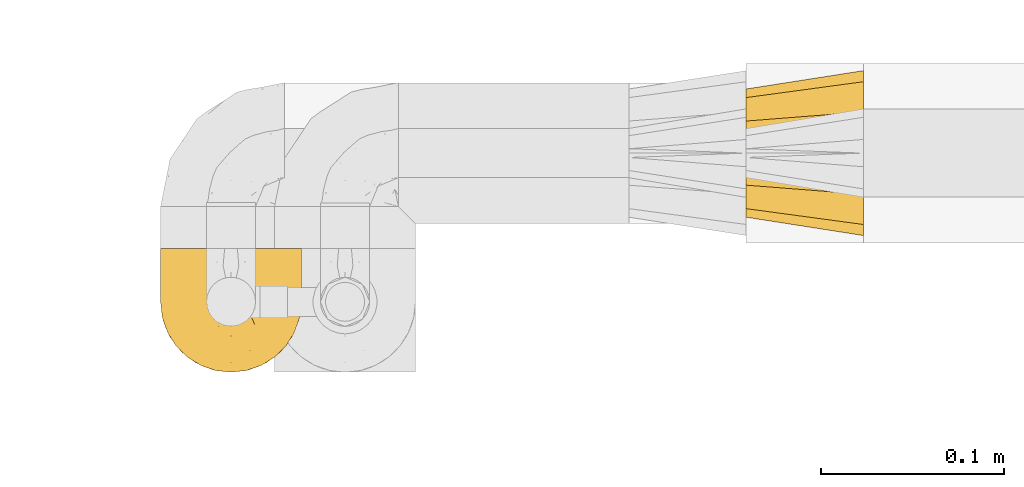
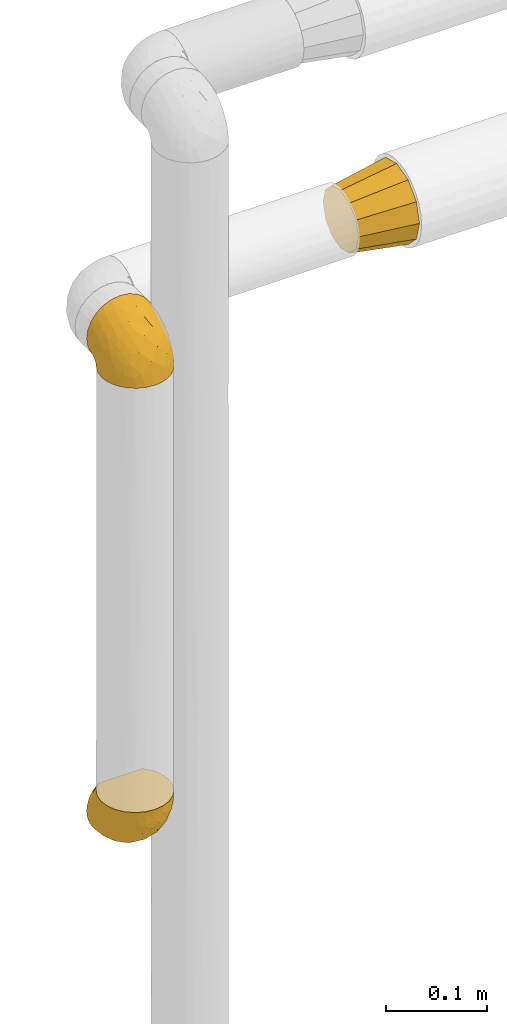
# One storey, part 334 of 827: 3 coverings.
"""IFC2X3 building model written with IfcOpenShell, lengths in millimetres."""

from ifc_helpers import new_model, entity, si_unit, converted_unit, derived_unit, direction, frame, origin, place, context, subcontext, project, spatial, faceted_brep, element, save


model = new_model("IFC2X3")

# Units and contexts
model_context = context("Model", 3, precision=0.01, world=origin(), true_north=direction((6.12303176911189e-17, 1.0)))
body_context = subcontext(model_context, "Body", "Model", "MODEL_VIEW")
ifc_project = project(units=[si_unit("LENGTHUNIT", "METRE", prefix="MILLI"), si_unit("AREAUNIT", "SQUARE_METRE"), si_unit("VOLUMEUNIT", "CUBIC_METRE"), converted_unit("PLANEANGLEUNIT", "DEGREE", entity("IfcRatioMeasure", 0.0174532925199433), si_unit("PLANEANGLEUNIT", "RADIAN"), dimensions=[0, 0, 0, 0, 0, 0, 0]), si_unit("MASSUNIT", "GRAM", prefix="KILO"), derived_unit("MASSDENSITYUNIT", [(si_unit("MASSUNIT", "GRAM", prefix="KILO"), 1), (si_unit("LENGTHUNIT", "METRE"), -3)]), derived_unit("MOMENTOFINERTIAUNIT", [(si_unit("LENGTHUNIT", "METRE"), 4)]), si_unit("TIMEUNIT", "SECOND"), si_unit("FREQUENCYUNIT", "HERTZ"), si_unit("THERMODYNAMICTEMPERATUREUNIT", "DEGREE_CELSIUS"), derived_unit("THERMALTRANSMITTANCEUNIT", [(si_unit("MASSUNIT", "GRAM", prefix="KILO"), 1), (si_unit("THERMODYNAMICTEMPERATUREUNIT", "KELVIN"), -1), (si_unit("TIMEUNIT", "SECOND"), -3)]), derived_unit("VOLUMETRICFLOWRATEUNIT", [(si_unit("LENGTHUNIT", "METRE"), 3), (si_unit("TIMEUNIT", "SECOND"), -1)]), derived_unit("MASSFLOWRATEUNIT", [(si_unit("MASSUNIT", "GRAM", prefix="KILO"), 1), (si_unit("TIMEUNIT", "SECOND"), -1)]), derived_unit("ROTATIONALFREQUENCYUNIT", [(si_unit("TIMEUNIT", "SECOND"), -1)]), si_unit("ELECTRICCURRENTUNIT", "AMPERE"), si_unit("ELECTRICVOLTAGEUNIT", "VOLT"), si_unit("POWERUNIT", "WATT"), si_unit("FORCEUNIT", "NEWTON", prefix="KILO"), si_unit("ILLUMINANCEUNIT", "LUX"), si_unit("LUMINOUSFLUXUNIT", "LUMEN"), si_unit("LUMINOUSINTENSITYUNIT", "CANDELA"), derived_unit("USERDEFINED", [(si_unit("MASSUNIT", "GRAM", prefix="KILO"), -1), (si_unit("LENGTHUNIT", "METRE"), -2), (si_unit("TIMEUNIT", "SECOND"), 3), (si_unit("LUMINOUSFLUXUNIT", "LUMEN"), 1)]), derived_unit("LINEARVELOCITYUNIT", [(si_unit("LENGTHUNIT", "METRE"), 1), (si_unit("TIMEUNIT", "SECOND"), -1)]), si_unit("PRESSUREUNIT", "PASCAL"), derived_unit("USERDEFINED", [(si_unit("LENGTHUNIT", "METRE"), -2), (si_unit("MASSUNIT", "GRAM", prefix="KILO"), 1), (si_unit("TIMEUNIT", "SECOND"), -2)]), derived_unit("LINEARFORCEUNIT", [(si_unit("MASSUNIT", "GRAM", prefix="KILO"), 1), (si_unit("LENGTHUNIT", "METRE"), 1), (si_unit("TIMEUNIT", "SECOND"), -2), (si_unit("LENGTHUNIT", "METRE"), -1)]), derived_unit("PLANARFORCEUNIT", [(si_unit("MASSUNIT", "GRAM", prefix="KILO"), 1), (si_unit("LENGTHUNIT", "METRE"), 1), (si_unit("TIMEUNIT", "SECOND"), -2), (si_unit("LENGTHUNIT", "METRE"), -2)])], contexts=[model_context])

# Site, building, storey
site_placement = place(None, origin())
site = spatial("IfcSite", under=ifc_project, at=site_placement, CompositionType="ELEMENT")
building_placement = place(site_placement, origin())
building = spatial("IfcBuilding", under=site, at=building_placement, CompositionType="ELEMENT")
storey_placement = place(building_placement, frame((0.0, 0.0, 28200.0)))
storey = spatial("IfcBuildingStorey", under=building, at=storey_placement, Name="08", CompositionType="ELEMENT", Elevation=28200.0)

# Coverings
covering_1_placement = place(storey_placement, frame((34953.73, 19373.39, 1669.3)))
element("IfcCovering", 1, at=covering_1_placement, inside=storey, Name=":ADSK_", ObjectType=":ADSK_", PredefinedType="INSULATION", context=body_context, shape_type="Brep", body=[
    faceted_brep([(74.68, 23.36, 1.6), (70.1, 16.07, 1.6), (64.01, 9.98, 1.6), (56.72, 5.4, 1.6), (48.6, 2.56, 1.6), (40.05, 1.6, 1.6), (31.49, 2.56, 1.6), (23.36, 5.41, 1.6), (16.07, 9.99, 1.6), (9.98, 16.08, 1.6), (5.4, 23.37, 1.6), (2.56, 31.49, 1.6), (1.6, 40.05, 1.6), (2.46, 48.15, 1.6), (5.01, 55.88, 1.6), (9.13, 62.9, 1.6), (14.62, 68.89, 1.6), (16.82, 68.89, 1.6), (18.56, 68.89, 1.6), (20.52, 68.89, 1.6), (22.49, 68.89, 1.6), (24.46, 68.89, 1.6), (26.42, 68.89, 1.6), (28.39, 68.89, 1.6), (30.36, 68.89, 1.6), (32.55, 68.89, 1.6), (34.75, 68.89, 1.6), (36.94, 68.89, 1.6), (39.13, 68.89, 1.6), (41.33, 68.89, 1.6), (43.52, 68.89, 1.6), (45.72, 68.89, 1.6), (47.91, 68.89, 1.6), (50.11, 68.89, 1.6), (52.3, 68.89, 1.6), (54.49, 68.89, 1.6), (56.69, 68.89, 1.6), (58.88, 68.89, 1.6), (61.08, 68.89, 1.6), (63.27, 68.89, 1.6), (65.47, 68.89, 1.6), (70.97, 62.89, 1.6), (75.09, 55.86, 1.6), (77.64, 48.13, 1.6), (78.5, 40.05, 1.6), (77.53, 31.49, 1.6), (14.62, 69.15, 1.85), (9.12, 69.15, 7.85), (5.0, 69.15, 14.87), (2.46, 69.15, 22.6), (1.6, 69.15, 30.7), (2.91, 69.15, 40.65), (6.75, 69.15, 49.92), (12.86, 69.15, 57.88), (20.82, 69.15, 63.99), (30.09, 69.15, 67.84), (40.05, 69.15, 69.15), (50.0, 69.15, 67.84), (59.27, 69.15, 63.99), (67.23, 69.15, 57.88), (73.34, 69.15, 49.92), (77.19, 69.15, 40.65), (78.5, 69.15, 30.7), (77.63, 69.15, 22.6), (75.09, 69.15, 14.87), (70.97, 69.15, 7.85), (65.47, 69.15, 1.85), (63.27, 69.15, 1.85), (62.29, 69.15, 1.85), (60.7, 69.15, 1.85), (59.11, 69.15, 1.85), (57.52, 69.15, 1.85), (55.93, 69.15, 1.85), (54.34, 69.15, 1.85), (52.76, 69.15, 1.85), (51.17, 69.15, 1.85), (49.58, 69.15, 1.85), (47.99, 69.15, 1.85), (46.4, 69.15, 1.85), (44.81, 69.15, 1.85), (43.22, 69.15, 1.85), (41.63, 69.15, 1.85), (40.05, 69.15, 1.85), (38.46, 69.15, 1.85), (36.87, 69.15, 1.85), (35.28, 69.15, 1.85), (33.69, 69.15, 1.85), (32.1, 69.15, 1.85), (30.51, 69.15, 1.85), (28.92, 69.15, 1.85), (27.33, 69.15, 1.85), (25.37, 69.15, 1.85), (23.4, 69.15, 1.85), (21.21, 69.15, 1.85), (19.01, 69.15, 1.85), (16.82, 69.15, 1.85), (42.32, 68.96, 1.77), (44.02, 68.97, 1.78), (47.13, 68.97, 1.77), (48.74, 68.97, 1.77), (23.57, 68.95, 1.76), (25.13, 68.96, 1.77), (61.34, 68.98, 1.79), (22.02, 68.97, 1.78), (29.72, 68.97, 1.78), (56.73, 68.98, 1.78), (55.14, 68.97, 1.78), (37.66, 68.97, 1.78), (64.12, 68.94, 1.74), (28.13, 68.98, 1.78), (26.62, 68.98, 1.78), (31.46, 68.96, 1.77), (16.16, 68.97, 1.78), (39.16, 68.98, 1.78), (50.37, 68.98, 1.78), (17.69, 68.97, 1.77), (19.17, 68.96, 1.77), (62.78, 68.97, 1.77), (58.35, 68.97, 1.78), (45.53, 68.98, 1.78), (59.91, 68.96, 1.77), (65.47, 68.97, 1.77), (65.47, 68.94, 1.72), (65.47, 68.92, 1.66), (14.62, 68.97, 1.77), (14.62, 69.02, 1.8), (14.62, 69.08, 1.82), (20.59, 68.98, 1.79), (32.99, 68.97, 1.78), (34.48, 68.98, 1.79), (51.91, 68.97, 1.78), (65.47, 69.08, 1.82), (65.47, 69.02, 1.8), (53.48, 68.96, 1.76), (14.62, 68.92, 1.66), (14.62, 68.94, 1.72), (40.77, 68.97, 1.78), (35.97, 68.96, 1.77), (7.84, 67.02, 9.41), (3.53, 63.33, 17.65), (8.32, 64.61, 7.41), (1.6, 49.27, 21.47), (2.19, 51.4, 15.21), (1.6, 43.94, 16.15), (1.6, 61.87, 28.75), (4.57, 61.54, 13.67), (3.96, 57.95, 12.79), (2.28, 56.12, 19.18), (1.6, 63.4, 29.16), (7.69, 65.41, 9.04), (3.53, 53.1, 7.41), (8.32, 63.04, 5.74), (7.84, 61.33, 3.72), (1.6, 41.99, 8.87), (1.6, 54.6, 26.8), (4.34, 56.6, 9.53), (1.6, 41.58, 7.34), (29.63, 13.72, 37.63), (27.34, 5.82, 17.92), (40.05, 6.74, 27.45), (2.39, 58.82, 37.01), (2.43, 51.58, 34.22), (9.07, 42.09, 45.87), (16.64, 46.12, 56.57), (9.54, 55.56, 52.31), (4.52, 52.38, 42.07), (4.52, 61.54, 44.74), (7.49, 23.76, 21.49), (7.49, 20.5, 11.02), (12.85, 14.64, 15.64), (2.35, 41.77, 26.02), (22.66, 16.28, 36.59), (32.9, 49.4, 65.49), (25.33, 52.34, 63.99), (40.05, 4.3, 15.2), (16.64, 58.67, 60.27), (19.99, 25.26, 45.25), (16.37, 20.17, 35.21), (3.26, 34.7, 22.52), (3.75, 28.67, 12.03), (19.58, 8.62, 13.32), (7.5, 33.37, 35.9), (4.04, 41.35, 33.87), (13.94, 17.15, 25.73), (19.58, 12.68, 26.34), (28.21, 21.47, 46.78), (24.75, 41.11, 59.54), (31.42, 37.53, 60.18), (26.2, 30.64, 53.93), (33.36, 26.66, 53.36), (40.05, 21.38, 49.36), (40.05, 14.06, 38.4), (40.05, 55.54, 66.44), (16.14, 35.17, 50.09), (12.85, 29.04, 41.08), (10.47, 24.34, 31.14), (6.49, 29.33, 28.19), (40.05, 43.3, 64.0), (40.05, 32.34, 56.68), (75.57, 57.75, 43.9), (47.37, 49.41, 65.46), (52.91, 27.85, 52.22), (50.46, 13.7, 37.61), (67.23, 14.63, 15.64), (60.5, 8.61, 13.31), (70.55, 48.85, 50.02), (63.45, 54.13, 59.28), (62.61, 37.84, 53.05), (72.6, 23.75, 21.48), (72.6, 20.49, 11.01), (76.34, 28.66, 12.03), (59.34, 20.83, 41.02), (77.76, 55.15, 35.39), (78.5, 54.6, 26.8), (78.5, 61.87, 28.75), (78.5, 41.58, 7.34), (53.16, 57.58, 65.81), (70.55, 59.91, 53.28), (48.88, 36.94, 59.8), (54.76, 45.72, 61.82), (52.74, 5.82, 17.91), (71.93, 37.91, 41.4), (75.79, 50.18, 40.48), (60.5, 12.67, 26.34), (77.86, 49.29, 31.68), (77.64, 42.64, 27.68), (78.5, 43.94, 16.15), (78.5, 49.27, 21.47), (67.23, 19.45, 28.05), (76.82, 34.7, 22.54), (78.5, 41.99, 8.87), (77.8, 62.29, 37.3), (67.23, 29.01, 41.07), (73.2, 31.47, 32.24), (67.66, 37.18, 47.4), (75.99, 43.45, 35.77), (76.57, 63.33, 17.65), (73.21, 67.23, 11.06), (71.93, 66.07, 8.55), (71.07, 65.22, 6.63), (75.09, 61.99, 12.77), (76.13, 57.95, 12.79), (76.57, 53.09, 7.41), (77.69, 56.84, 18.97), (72.26, 61.33, 3.72), (71.77, 63.06, 5.76), (77.9, 51.41, 15.21), (75.75, 56.61, 9.52)], [[[0, 1, 2, 3, 4, 5, 6, 7, 8, 9, 10, 11, 12, 13, 14, 15, 16, 17, 18, 19, 20, 21, 22, 23, 24, 25, 26, 27, 28, 29, 30, 31, 32, 33, 34, 35, 36, 37, 38, 39, 40, 41, 42, 43, 44, 45]], [[46, 47, 48, 49, 50, 51, 52, 53, 54, 55, 56, 57, 58, 59, 60, 61, 62, 63, 64, 65, 66, 67, 68, 69, 70, 71, 72, 73, 74, 75, 76, 77, 78, 79, 80, 81, 82, 83, 84, 85, 86, 87, 88, 89, 90, 91, 92, 93, 94, 95]], [[96, 97, 30]], [[98, 77, 99]], [[100, 101, 21]], [[69, 68, 102]], [[20, 19, 103]], [[24, 23, 104]], [[20, 103, 100]], [[72, 105, 106]], [[84, 83, 107]], [[89, 88, 104]], [[108, 67, 66]], [[109, 110, 90]], [[111, 25, 24]], [[112, 17, 16]], [[82, 113, 83]], [[109, 23, 22]], [[114, 76, 75]], [[105, 36, 106]], [[104, 111, 24]], [[18, 115, 116]], [[97, 96, 80]], [[67, 108, 117]], [[105, 71, 118]], [[31, 97, 119]], [[102, 120, 69]], [[108, 121, 122, 123, 40]], [[112, 95, 115]], [[17, 115, 18]], [[94, 116, 115]], [[117, 68, 67]], [[38, 117, 39]], [[112, 124, 125, 126, 46]], [[17, 112, 115]], [[70, 120, 118]], [[39, 117, 108]], [[120, 38, 37]], [[120, 37, 118]], [[120, 70, 69]], [[116, 94, 127]], [[128, 86, 129]], [[117, 38, 102]], [[74, 130, 75]], [[99, 33, 32]], [[115, 95, 94]], [[39, 108, 40]], [[108, 66, 131, 132, 121]], [[105, 72, 71]], [[118, 37, 36]], [[71, 70, 118]], [[35, 106, 36]], [[36, 105, 118]], [[35, 133, 106]], [[74, 73, 133]], [[106, 133, 73]], [[99, 114, 33]], [[133, 35, 34]], [[73, 72, 106]], [[95, 112, 46]], [[112, 16, 134, 135, 124]], [[130, 114, 75]], [[99, 76, 114]], [[114, 130, 33]], [[34, 33, 130]], [[78, 77, 98]], [[98, 119, 78]], [[130, 133, 34]], [[133, 130, 74]], [[79, 97, 80]], [[98, 99, 32]], [[98, 32, 31]], [[77, 76, 99]], [[97, 79, 119]], [[136, 96, 29]], [[30, 97, 31]], [[136, 29, 28]], [[81, 80, 96]], [[29, 96, 30]], [[31, 119, 98]], [[119, 79, 78]], [[96, 136, 81]], [[82, 81, 136]], [[113, 107, 83]], [[84, 107, 137]], [[107, 27, 137]], [[113, 28, 107]], [[27, 107, 28]], [[85, 84, 137]], [[137, 27, 26]], [[113, 136, 28]], [[136, 113, 82]], [[109, 89, 104]], [[86, 85, 129]], [[89, 109, 90]], [[111, 87, 128]], [[26, 129, 137]], [[88, 111, 104]], [[25, 111, 128]], [[22, 110, 109]], [[23, 109, 104]], [[110, 91, 90]], [[100, 92, 101]], [[110, 22, 101]], [[91, 110, 101]], [[116, 19, 18]], [[111, 88, 87]], [[127, 103, 19]], [[25, 128, 26]], [[86, 128, 87]], [[128, 129, 26]], [[137, 129, 85]], [[120, 102, 38]], [[117, 102, 68]], [[91, 101, 92]], [[21, 101, 22]], [[93, 92, 103]], [[100, 21, 20]], [[100, 103, 92]], [[127, 93, 103]], [[93, 127, 94]], [[116, 127, 19]], [[126, 138, 47]], [[48, 138, 139]], [[140, 125, 124]], [[141, 142, 143]], [[144, 49, 139]], [[145, 140, 146]], [[48, 139, 49]], [[139, 145, 147]], [[49, 144, 148, 50]], [[126, 125, 149]], [[14, 13, 150]], [[151, 146, 140]], [[149, 140, 145]], [[152, 151, 135]], [[152, 14, 150]], [[16, 15, 134]], [[13, 153, 150]], [[124, 151, 140]], [[141, 147, 142]], [[14, 152, 15]], [[15, 152, 134]], [[47, 46, 126]], [[139, 154, 144]], [[138, 48, 47]], [[125, 140, 149]], [[135, 134, 152]], [[146, 155, 142]], [[145, 146, 147]], [[149, 139, 138]], [[147, 141, 154]], [[147, 146, 142]], [[139, 147, 154]], [[139, 149, 145]], [[149, 138, 126]], [[155, 146, 151]], [[150, 143, 142]], [[152, 155, 151]], [[150, 142, 155]], [[13, 12, 156, 153]], [[153, 143, 150]], [[152, 150, 155]], [[151, 124, 135]], [[157, 158, 159]], [[160, 154, 161]], [[162, 163, 164]], [[165, 166, 160]], [[167, 168, 169]], [[141, 170, 161]], [[156, 12, 11]], [[158, 157, 171]], [[172, 55, 173]], [[158, 6, 174]], [[175, 54, 53]], [[52, 166, 164]], [[52, 164, 53]], [[54, 175, 173]], [[166, 52, 51]], [[176, 177, 171]], [[178, 143, 179]], [[156, 11, 179]], [[8, 7, 180]], [[169, 9, 8]], [[179, 143, 153, 156]], [[179, 11, 10]], [[168, 179, 10]], [[181, 162, 182]], [[179, 167, 178]], [[183, 184, 177]], [[183, 169, 184]], [[176, 171, 185]], [[172, 186, 187]], [[158, 7, 6]], [[159, 158, 174]], [[184, 180, 158]], [[54, 173, 55]], [[180, 169, 8]], [[188, 189, 187]], [[9, 168, 10]], [[186, 188, 187]], [[190, 157, 159, 191]], [[55, 172, 192]], [[176, 193, 194]], [[161, 170, 182]], [[162, 164, 165]], [[175, 164, 163]], [[51, 50, 148]], [[167, 195, 196]], [[178, 182, 170]], [[6, 5, 174]], [[158, 180, 7]], [[169, 180, 184]], [[169, 168, 9]], [[179, 168, 167]], [[182, 162, 165]], [[162, 194, 193]], [[161, 165, 160]], [[195, 181, 196]], [[192, 172, 197]], [[192, 56, 55]], [[189, 190, 198]], [[198, 197, 187]], [[172, 187, 197]], [[185, 189, 188]], [[198, 187, 189]], [[186, 172, 173]], [[173, 163, 186]], [[193, 186, 163]], [[176, 185, 188]], [[185, 157, 190]], [[188, 186, 193]], [[177, 176, 194]], [[188, 193, 176]], [[162, 193, 163]], [[195, 177, 194]], [[171, 177, 184]], [[181, 195, 194]], [[183, 167, 169]], [[162, 181, 194]], [[196, 182, 178]], [[158, 171, 184]], [[171, 157, 185]], [[177, 195, 183]], [[167, 183, 195]], [[182, 196, 181]], [[178, 170, 143]], [[178, 167, 196]], [[164, 175, 53]], [[173, 175, 163]], [[160, 51, 148]], [[164, 166, 165]], [[51, 160, 166]], [[160, 148, 144, 154]], [[141, 161, 154]], [[182, 165, 161]], [[190, 189, 185]], [[143, 170, 141]], [[60, 199, 61]], [[197, 200, 192]], [[201, 190, 202]], [[200, 57, 192]], [[203, 204, 2]], [[205, 206, 207]], [[208, 209, 210]], [[211, 207, 201]], [[212, 213, 214]], [[45, 215, 210]], [[216, 206, 58]], [[45, 44, 215]], [[59, 217, 60]], [[60, 217, 199]], [[0, 45, 210]], [[218, 201, 219]], [[202, 159, 220]], [[205, 221, 222]], [[223, 204, 203]], [[1, 203, 2]], [[57, 200, 216]], [[220, 3, 204]], [[220, 174, 4]], [[1, 0, 209]], [[212, 224, 213]], [[225, 226, 227]], [[228, 223, 203]], [[208, 210, 229]], [[210, 226, 229]], [[3, 220, 4]], [[58, 206, 59]], [[209, 203, 1]], [[202, 220, 223]], [[228, 203, 208]], [[202, 211, 201]], [[3, 2, 204]], [[202, 190, 191, 159]], [[210, 215, 230, 226]], [[199, 212, 231]], [[232, 233, 221]], [[233, 208, 229]], [[207, 206, 219]], [[217, 206, 205]], [[227, 224, 225]], [[233, 232, 228]], [[201, 207, 219]], [[234, 232, 221]], [[218, 219, 200]], [[202, 223, 211]], [[174, 220, 159]], [[174, 5, 4]], [[61, 231, 62]], [[220, 204, 223]], [[210, 209, 0]], [[203, 209, 208]], [[225, 233, 229]], [[224, 227, 213]], [[221, 233, 235]], [[57, 56, 192]], [[198, 218, 197]], [[200, 219, 216]], [[201, 198, 190]], [[197, 218, 200]], [[198, 201, 218]], [[206, 216, 219]], [[58, 57, 216]], [[231, 212, 214]], [[222, 212, 199]], [[228, 211, 223]], [[207, 211, 232]], [[62, 231, 214]], [[199, 231, 61]], [[233, 228, 208]], [[211, 228, 232]], [[222, 221, 235]], [[234, 205, 207]], [[206, 217, 59]], [[199, 217, 205]], [[205, 222, 199]], [[224, 222, 235]], [[222, 224, 212]], [[224, 235, 225]], [[233, 225, 235]], [[226, 225, 229]], [[205, 234, 221]], [[207, 232, 234]], [[63, 214, 236]], [[214, 213, 236]], [[214, 63, 62]], [[237, 236, 238]], [[238, 132, 131]], [[236, 237, 64]], [[239, 240, 241]], [[63, 236, 64]], [[131, 66, 65]], [[237, 131, 65]], [[242, 230, 43]], [[237, 65, 64]], [[239, 121, 132]], [[42, 242, 43]], [[241, 240, 243]], [[41, 123, 244]], [[43, 230, 215, 44]], [[244, 122, 245]], [[227, 246, 243]], [[241, 247, 245]], [[121, 239, 245]], [[41, 40, 123]], [[132, 238, 239]], [[244, 42, 41]], [[131, 237, 238]], [[240, 239, 238]], [[245, 239, 241]], [[247, 241, 246]], [[247, 244, 245]], [[238, 236, 240]], [[243, 236, 213]], [[236, 243, 240]], [[227, 226, 246]], [[243, 213, 227]], [[242, 246, 226]], [[243, 246, 241]], [[246, 242, 247]], [[244, 247, 242]], [[242, 226, 230]], [[42, 244, 242]], [[122, 244, 123]], [[122, 121, 245]]]),
])
covering_2_placement = place(storey_placement, frame((34953.73, 19373.39, 1090.4)))
element("IfcCovering", 2, at=covering_2_placement, inside=storey, Name=":ADSK_", ObjectType=":ADSK_", PredefinedType="INSULATION", context=body_context, shape_type="Brep", body=[
    faceted_brep([(74.68, 69.15, 23.36), (70.1, 69.15, 16.07), (64.01, 69.15, 9.98), (56.72, 69.15, 5.4), (48.6, 69.15, 2.56), (40.05, 69.15, 1.6), (31.49, 69.15, 2.56), (23.36, 69.15, 5.41), (16.07, 69.15, 9.99), (9.98, 69.15, 16.08), (5.4, 69.15, 23.37), (2.56, 69.15, 31.49), (1.6, 69.15, 40.05), (2.46, 69.15, 48.15), (5.01, 69.15, 55.88), (9.13, 69.15, 62.9), (14.62, 69.15, 68.89), (16.82, 69.15, 68.89), (18.56, 69.15, 68.89), (20.52, 69.15, 68.89), (22.49, 69.15, 68.89), (24.46, 69.15, 68.89), (26.42, 69.15, 68.89), (28.39, 69.15, 68.89), (30.36, 69.15, 68.89), (32.55, 69.15, 68.89), (34.75, 69.15, 68.89), (36.94, 69.15, 68.89), (39.13, 69.15, 68.89), (41.33, 69.15, 68.89), (43.52, 69.15, 68.89), (45.72, 69.15, 68.89), (47.91, 69.15, 68.89), (50.11, 69.15, 68.89), (52.3, 69.15, 68.89), (54.49, 69.15, 68.89), (56.69, 69.15, 68.89), (58.88, 69.15, 68.89), (61.08, 69.15, 68.89), (63.27, 69.15, 68.89), (65.47, 69.15, 68.89), (70.97, 69.15, 62.89), (75.09, 69.15, 55.86), (77.64, 69.15, 48.13), (78.5, 69.15, 40.05), (77.53, 69.15, 31.49), (14.62, 68.89, 69.15), (9.12, 62.89, 69.15), (5.0, 55.87, 69.15), (2.46, 48.14, 69.15), (1.6, 40.05, 69.15), (2.91, 30.09, 69.15), (6.75, 20.82, 69.15), (12.86, 12.86, 69.15), (20.82, 6.75, 69.15), (30.09, 2.91, 69.15), (40.05, 1.6, 69.15), (50.0, 2.91, 69.15), (59.27, 6.75, 69.15), (67.23, 12.86, 69.15), (73.34, 20.82, 69.15), (77.19, 30.09, 69.15), (78.5, 40.05, 69.15), (77.63, 48.14, 69.15), (75.09, 55.87, 69.15), (70.97, 62.89, 69.15), (65.47, 68.89, 69.15), (63.27, 68.89, 69.15), (62.29, 68.89, 69.15), (60.7, 68.89, 69.15), (59.11, 68.89, 69.15), (57.52, 68.89, 69.15), (55.93, 68.89, 69.15), (54.34, 68.89, 69.15), (52.76, 68.89, 69.15), (51.17, 68.89, 69.15), (49.58, 68.89, 69.15), (47.99, 68.89, 69.15), (46.4, 68.89, 69.15), (44.81, 68.89, 69.15), (43.22, 68.89, 69.15), (41.63, 68.89, 69.15), (40.05, 68.89, 69.15), (38.46, 68.89, 69.15), (36.87, 68.89, 69.15), (35.28, 68.89, 69.15), (33.69, 68.89, 69.15), (32.1, 68.89, 69.15), (30.51, 68.89, 69.15), (28.92, 68.89, 69.15), (27.33, 68.89, 69.15), (25.37, 68.89, 69.15), (23.4, 68.89, 69.15), (21.21, 68.89, 69.15), (19.01, 68.89, 69.15), (16.82, 68.89, 69.15), (42.32, 68.97, 68.96), (44.02, 68.96, 68.97), (47.13, 68.97, 68.97), (48.74, 68.97, 68.97), (23.57, 68.98, 68.95), (25.13, 68.97, 68.96), (61.34, 68.96, 68.98), (22.02, 68.96, 68.97), (29.72, 68.96, 68.97), (56.73, 68.96, 68.98), (55.14, 68.96, 68.97), (37.66, 68.96, 68.97), (64.12, 69.0, 68.94), (28.13, 68.96, 68.98), (26.62, 68.96, 68.98), (31.46, 68.97, 68.96), (16.16, 68.96, 68.97), (39.16, 68.96, 68.98), (50.37, 68.96, 68.98), (17.69, 68.97, 68.97), (19.17, 68.97, 68.96), (62.78, 68.97, 68.97), (58.35, 68.96, 68.97), (45.53, 68.96, 68.98), (59.91, 68.97, 68.96), (65.47, 68.97, 68.97), (65.47, 69.02, 68.94), (65.47, 69.08, 68.92), (14.62, 68.97, 68.97), (14.62, 68.94, 69.02), (14.62, 68.92, 69.08), (20.59, 68.96, 68.98), (32.99, 68.96, 68.97), (34.48, 68.95, 68.98), (51.91, 68.96, 68.97), (65.47, 68.92, 69.08), (65.47, 68.94, 69.02), (53.48, 68.98, 68.96), (14.62, 69.08, 68.92), (14.62, 69.02, 68.94), (40.77, 68.96, 68.97), (35.97, 68.97, 68.96), (7.84, 61.33, 67.02), (3.53, 53.1, 63.33), (8.32, 63.33, 64.61), (2.19, 55.53, 51.4), (3.53, 63.33, 53.1), (1.6, 54.6, 43.94), (1.6, 41.99, 61.87), (4.57, 57.07, 61.54), (3.96, 57.95, 57.95), (2.28, 51.56, 56.12), (1.6, 41.58, 63.4), (7.69, 61.7, 65.41), (8.32, 65.0, 63.04), (7.84, 67.02, 61.33), (1.6, 61.87, 41.99), (1.6, 49.27, 49.27), (1.6, 43.94, 54.6), (4.34, 61.21, 56.6), (1.6, 63.4, 41.58), (29.63, 33.11, 13.72), (27.34, 52.82, 5.82), (40.05, 43.3, 6.74), (2.39, 33.73, 58.82), (2.43, 36.52, 51.58), (9.07, 24.87, 42.09), (16.64, 14.17, 46.12), (9.54, 18.43, 55.56), (4.52, 28.67, 52.38), (4.52, 26.0, 61.54), (7.49, 49.25, 23.76), (7.49, 59.72, 20.5), (12.85, 55.1, 14.64), (2.35, 44.72, 41.77), (22.66, 34.15, 16.28), (32.9, 5.25, 49.4), (25.33, 6.75, 52.34), (40.05, 55.54, 4.3), (16.64, 10.47, 58.67), (19.99, 25.49, 25.26), (16.37, 35.53, 20.17), (3.26, 48.22, 34.7), (3.75, 58.71, 28.67), (19.58, 57.42, 8.62), (7.5, 34.84, 33.37), (4.04, 36.87, 41.35), (13.94, 45.01, 17.15), (19.58, 44.4, 12.68), (28.21, 23.96, 21.47), (24.75, 11.2, 41.11), (31.42, 10.56, 37.53), (26.2, 16.81, 30.64), (33.36, 17.38, 26.66), (40.05, 21.38, 21.38), (40.05, 32.34, 14.06), (40.05, 4.3, 55.54), (16.14, 20.65, 35.17), (12.85, 29.66, 29.04), (10.47, 39.6, 24.34), (6.49, 42.55, 29.33), (40.05, 6.74, 43.3), (40.05, 14.06, 32.34), (75.57, 26.84, 57.75), (47.37, 5.28, 49.41), (52.91, 18.52, 27.85), (50.46, 33.13, 13.7), (67.23, 55.1, 14.63), (60.5, 57.43, 8.61), (70.55, 20.72, 48.85), (63.45, 11.46, 54.13), (62.61, 17.69, 37.84), (72.6, 49.26, 23.75), (72.6, 59.73, 20.49), (76.34, 58.71, 28.66), (59.34, 29.72, 20.83), (77.76, 35.35, 55.15), (78.5, 43.94, 54.6), (78.5, 41.99, 61.87), (78.5, 63.4, 41.58), (53.16, 4.93, 57.58), (70.55, 17.46, 59.91), (48.88, 10.94, 36.94), (54.76, 8.92, 45.72), (52.74, 52.83, 5.82), (71.93, 29.34, 37.91), (75.79, 30.26, 50.18), (60.5, 44.4, 12.67), (77.86, 39.06, 49.29), (77.64, 43.06, 42.64), (78.5, 54.6, 43.94), (78.5, 49.27, 49.27), (67.23, 42.69, 19.45), (76.82, 48.2, 34.7), (78.5, 61.87, 41.99), (77.8, 33.44, 62.29), (67.23, 29.67, 29.01), (73.2, 38.5, 31.47), (67.66, 23.35, 37.18), (75.99, 34.97, 43.45), (76.57, 53.1, 63.33), (73.21, 59.68, 67.23), (71.93, 62.19, 66.07), (71.07, 64.11, 65.22), (75.09, 57.97, 61.99), (76.13, 57.95, 57.95), (76.57, 63.33, 53.09), (77.69, 51.77, 56.84), (72.26, 67.02, 61.33), (71.77, 64.98, 63.06), (77.9, 55.53, 51.41), (75.75, 61.22, 56.61)], [[[0, 1, 2, 3, 4, 5, 6, 7, 8, 9, 10, 11, 12, 13, 14, 15, 16, 17, 18, 19, 20, 21, 22, 23, 24, 25, 26, 27, 28, 29, 30, 31, 32, 33, 34, 35, 36, 37, 38, 39, 40, 41, 42, 43, 44, 45]], [[46, 47, 48, 49, 50, 51, 52, 53, 54, 55, 56, 57, 58, 59, 60, 61, 62, 63, 64, 65, 66, 67, 68, 69, 70, 71, 72, 73, 74, 75, 76, 77, 78, 79, 80, 81, 82, 83, 84, 85, 86, 87, 88, 89, 90, 91, 92, 93, 94, 95]], [[96, 97, 30]], [[98, 77, 99]], [[100, 101, 21]], [[69, 68, 102]], [[20, 19, 103]], [[24, 23, 104]], [[20, 103, 100]], [[72, 105, 106]], [[84, 83, 107]], [[89, 88, 104]], [[108, 67, 66]], [[109, 110, 90]], [[111, 25, 24]], [[112, 17, 16]], [[82, 113, 83]], [[109, 23, 22]], [[114, 76, 75]], [[105, 36, 106]], [[104, 111, 24]], [[18, 115, 116]], [[97, 96, 80]], [[67, 108, 117]], [[105, 71, 118]], [[31, 97, 119]], [[102, 120, 69]], [[108, 121, 122, 123, 40]], [[112, 95, 115]], [[17, 115, 18]], [[94, 116, 115]], [[117, 68, 67]], [[38, 117, 39]], [[112, 124, 125, 126, 46]], [[17, 112, 115]], [[70, 120, 118]], [[39, 117, 108]], [[120, 38, 37]], [[120, 37, 118]], [[120, 70, 69]], [[116, 94, 127]], [[128, 86, 129]], [[117, 38, 102]], [[74, 130, 75]], [[99, 33, 32]], [[115, 95, 94]], [[39, 108, 40]], [[108, 66, 131, 132, 121]], [[105, 72, 71]], [[118, 37, 36]], [[71, 70, 118]], [[35, 106, 36]], [[36, 105, 118]], [[35, 133, 106]], [[74, 73, 133]], [[106, 133, 73]], [[99, 114, 33]], [[133, 35, 34]], [[73, 72, 106]], [[95, 112, 46]], [[112, 16, 134, 135, 124]], [[130, 114, 75]], [[99, 76, 114]], [[114, 130, 33]], [[34, 33, 130]], [[78, 77, 98]], [[98, 119, 78]], [[130, 133, 34]], [[133, 130, 74]], [[79, 97, 80]], [[98, 99, 32]], [[98, 32, 31]], [[77, 76, 99]], [[97, 79, 119]], [[136, 96, 29]], [[30, 97, 31]], [[136, 29, 28]], [[81, 80, 96]], [[29, 96, 30]], [[31, 119, 98]], [[119, 79, 78]], [[96, 136, 81]], [[82, 81, 136]], [[113, 107, 83]], [[84, 107, 137]], [[107, 27, 137]], [[113, 28, 107]], [[27, 107, 28]], [[85, 84, 137]], [[137, 27, 26]], [[113, 136, 28]], [[136, 113, 82]], [[109, 89, 104]], [[86, 85, 129]], [[89, 109, 90]], [[111, 87, 128]], [[26, 129, 137]], [[88, 111, 104]], [[25, 111, 128]], [[22, 110, 109]], [[23, 109, 104]], [[110, 91, 90]], [[100, 92, 101]], [[110, 22, 101]], [[91, 110, 101]], [[116, 19, 18]], [[111, 88, 87]], [[127, 103, 19]], [[25, 128, 26]], [[86, 128, 87]], [[128, 129, 26]], [[137, 129, 85]], [[120, 102, 38]], [[117, 102, 68]], [[91, 101, 92]], [[21, 101, 22]], [[93, 92, 103]], [[100, 21, 20]], [[100, 103, 92]], [[127, 93, 103]], [[93, 127, 94]], [[116, 127, 19]], [[126, 138, 47]], [[48, 138, 139]], [[140, 125, 124]], [[141, 142, 143]], [[144, 49, 139]], [[145, 140, 146]], [[48, 139, 49]], [[139, 145, 147]], [[49, 144, 148, 50]], [[126, 125, 149]], [[14, 13, 142]], [[150, 146, 140]], [[149, 140, 145]], [[151, 150, 135]], [[151, 14, 142]], [[16, 15, 134]], [[13, 152, 142]], [[124, 150, 140]], [[141, 143, 153]], [[14, 151, 15]], [[15, 151, 134]], [[47, 46, 126]], [[139, 154, 144]], [[138, 48, 47]], [[125, 140, 149]], [[135, 134, 151]], [[146, 155, 141]], [[145, 146, 147]], [[149, 139, 138]], [[147, 153, 154]], [[147, 146, 141]], [[139, 147, 154]], [[139, 149, 145]], [[149, 138, 126]], [[147, 141, 153]], [[146, 150, 155]], [[151, 155, 150]], [[142, 141, 155]], [[13, 12, 156, 152]], [[152, 143, 142]], [[151, 142, 155]], [[150, 124, 135]], [[157, 158, 159]], [[160, 154, 161]], [[162, 163, 164]], [[165, 166, 160]], [[167, 168, 169]], [[153, 170, 161]], [[156, 12, 11]], [[158, 157, 171]], [[172, 55, 173]], [[158, 6, 174]], [[175, 54, 53]], [[52, 166, 164]], [[52, 164, 53]], [[54, 175, 173]], [[166, 52, 51]], [[176, 177, 171]], [[178, 143, 179]], [[156, 11, 179]], [[8, 7, 180]], [[169, 9, 8]], [[179, 143, 152, 156]], [[179, 11, 10]], [[168, 179, 10]], [[181, 162, 182]], [[179, 167, 178]], [[183, 184, 177]], [[183, 169, 184]], [[176, 171, 185]], [[172, 186, 187]], [[158, 7, 6]], [[159, 158, 174]], [[184, 180, 158]], [[54, 173, 55]], [[180, 169, 8]], [[188, 189, 187]], [[9, 168, 10]], [[186, 188, 187]], [[190, 157, 159, 191]], [[55, 172, 192]], [[176, 193, 194]], [[161, 170, 182]], [[162, 164, 165]], [[175, 164, 163]], [[51, 50, 148]], [[167, 195, 196]], [[178, 182, 170]], [[6, 5, 174]], [[158, 180, 7]], [[169, 180, 184]], [[169, 168, 9]], [[179, 168, 167]], [[182, 162, 165]], [[162, 194, 193]], [[161, 165, 160]], [[195, 181, 196]], [[192, 172, 197]], [[192, 56, 55]], [[189, 190, 198]], [[198, 197, 187]], [[172, 187, 197]], [[185, 189, 188]], [[198, 187, 189]], [[186, 172, 173]], [[173, 163, 186]], [[193, 186, 163]], [[176, 185, 188]], [[185, 157, 190]], [[188, 186, 193]], [[177, 176, 194]], [[188, 193, 176]], [[162, 193, 163]], [[195, 177, 194]], [[171, 177, 184]], [[181, 195, 194]], [[183, 167, 169]], [[162, 181, 194]], [[196, 182, 178]], [[158, 171, 184]], [[171, 157, 185]], [[177, 195, 183]], [[167, 183, 195]], [[182, 196, 181]], [[178, 170, 143]], [[178, 167, 196]], [[164, 175, 53]], [[173, 175, 163]], [[160, 51, 148]], [[164, 166, 165]], [[51, 160, 166]], [[160, 148, 144, 154]], [[153, 161, 154]], [[182, 165, 161]], [[190, 189, 185]], [[143, 170, 153]], [[60, 199, 61]], [[197, 200, 192]], [[201, 190, 202]], [[200, 57, 192]], [[203, 204, 2]], [[205, 206, 207]], [[208, 209, 210]], [[211, 207, 201]], [[212, 213, 214]], [[45, 215, 210]], [[216, 206, 58]], [[45, 44, 215]], [[59, 217, 60]], [[60, 217, 199]], [[0, 45, 210]], [[218, 201, 219]], [[202, 159, 220]], [[205, 221, 222]], [[223, 204, 203]], [[1, 203, 2]], [[57, 200, 216]], [[220, 3, 204]], [[220, 174, 4]], [[1, 0, 209]], [[212, 224, 213]], [[225, 226, 227]], [[228, 223, 203]], [[208, 210, 229]], [[210, 226, 229]], [[3, 220, 4]], [[58, 206, 59]], [[209, 203, 1]], [[202, 220, 223]], [[228, 203, 208]], [[202, 211, 201]], [[3, 2, 204]], [[202, 190, 191, 159]], [[210, 215, 230, 226]], [[199, 212, 231]], [[232, 233, 221]], [[233, 208, 229]], [[207, 206, 219]], [[217, 206, 205]], [[227, 224, 225]], [[233, 232, 228]], [[201, 207, 219]], [[234, 232, 221]], [[218, 219, 200]], [[202, 223, 211]], [[174, 220, 159]], [[174, 5, 4]], [[61, 231, 62]], [[220, 204, 223]], [[210, 209, 0]], [[203, 209, 208]], [[225, 233, 229]], [[224, 227, 213]], [[221, 233, 235]], [[57, 56, 192]], [[198, 218, 197]], [[200, 219, 216]], [[201, 198, 190]], [[197, 218, 200]], [[198, 201, 218]], [[206, 216, 219]], [[58, 57, 216]], [[231, 212, 214]], [[222, 212, 199]], [[228, 211, 223]], [[207, 211, 232]], [[62, 231, 214]], [[199, 231, 61]], [[233, 228, 208]], [[211, 228, 232]], [[222, 221, 235]], [[234, 205, 207]], [[206, 217, 59]], [[199, 217, 205]], [[205, 222, 199]], [[224, 222, 235]], [[222, 224, 212]], [[224, 235, 225]], [[233, 225, 235]], [[226, 225, 229]], [[205, 234, 221]], [[207, 232, 234]], [[63, 214, 236]], [[214, 213, 236]], [[214, 63, 62]], [[237, 236, 238]], [[238, 132, 131]], [[236, 237, 64]], [[239, 240, 241]], [[63, 236, 64]], [[131, 66, 65]], [[237, 131, 65]], [[242, 230, 43]], [[237, 65, 64]], [[239, 121, 132]], [[42, 242, 43]], [[241, 240, 243]], [[41, 123, 244]], [[43, 230, 215, 44]], [[244, 122, 245]], [[227, 246, 243]], [[245, 241, 247]], [[121, 239, 245]], [[41, 40, 123]], [[132, 238, 239]], [[244, 42, 41]], [[131, 237, 238]], [[240, 239, 238]], [[245, 239, 241]], [[247, 241, 246]], [[247, 244, 245]], [[238, 236, 240]], [[243, 236, 213]], [[236, 243, 240]], [[246, 241, 243]], [[243, 213, 227]], [[226, 242, 246]], [[227, 226, 246]], [[246, 242, 247]], [[244, 247, 242]], [[242, 226, 230]], [[42, 244, 242]], [[122, 244, 123]], [[122, 121, 245]]]),
])
covering_3_placement = place(storey_placement, frame((35275.02, 19448.01, 1653.4)))
element("IfcCovering", 3, at=covering_3_placement, inside=storey, Name=":ADSK_", ObjectType=":ADSK_", PredefinedType="INSULATION", context=body_context, shape_type="Brep", body=[
    faceted_brep([(0.0, 46.6, 11.6), (0.0, 37.85, 13.94), (0.0, 29.1, 16.28), (0.0, 22.69, 22.69), (0.0, 16.28, 29.1), (0.0, 13.94, 37.85), (0.0, 11.6, 46.6), (0.0, 13.94, 55.35), (0.0, 16.28, 64.1), (0.0, 22.69, 70.5), (0.0, 29.1, 76.91), (0.0, 37.85, 79.25), (0.0, 46.6, 81.6), (0.0, 55.35, 79.25), (0.0, 64.1, 76.91), (0.0, 70.5, 70.5), (0.0, 76.91, 64.1), (0.0, 79.25, 55.35), (0.0, 81.6, 46.6), (0.0, 79.25, 37.85), (0.0, 76.91, 29.1), (0.0, 70.5, 22.69), (0.0, 64.1, 16.28), (0.0, 55.35, 13.94), (64.0, 15.86, 77.33), (64.0, 7.62, 69.1), (64.0, 5.02, 59.38), (64.0, 1.6, 46.6), (64.0, 5.02, 33.81), (64.0, 7.62, 24.1), (64.0, 15.86, 15.86), (64.0, 24.1, 7.62), (64.0, 33.81, 5.02), (64.0, 46.6, 1.6), (64.0, 59.38, 5.02), (64.0, 69.1, 7.62), (64.0, 77.33, 15.86), (64.0, 85.57, 24.1), (64.0, 88.17, 33.81), (64.0, 91.6, 46.6), (64.0, 88.17, 59.38), (64.0, 85.57, 69.1), (64.0, 77.33, 77.33), (64.0, 69.1, 85.57), (64.0, 59.38, 88.17), (64.0, 46.6, 91.6), (64.0, 33.81, 88.17), (64.0, 24.1, 85.57)], [[[0, 1, 2, 3, 4, 5, 6, 7, 8, 9, 10, 11, 12, 13, 14, 15, 16, 17, 18, 19, 20, 21, 22, 23]], [[24, 25, 26, 27, 28, 29, 30, 31, 32, 33, 34, 35, 36, 37, 38, 39, 40, 41, 42, 43, 44, 45, 46, 47]], [[22, 35, 34, 33, 0, 23]], [[37, 36, 35, 22, 21, 20]], [[19, 18, 39, 38, 37, 20]], [[4, 29, 28, 27, 6, 5]], [[31, 30, 29, 4, 3, 2]], [[1, 0, 33, 32, 31, 2]], [[10, 47, 46, 45, 12, 11]], [[25, 24, 47, 10, 9, 8]], [[7, 6, 27, 26, 25, 8]], [[16, 41, 40, 39, 18, 17]], [[43, 42, 41, 16, 15, 14]], [[13, 12, 45, 44, 43, 14]]]),
])

save(model, "model.ifc")
